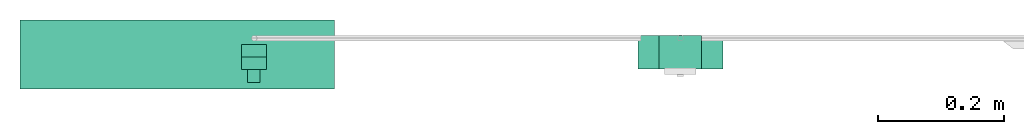
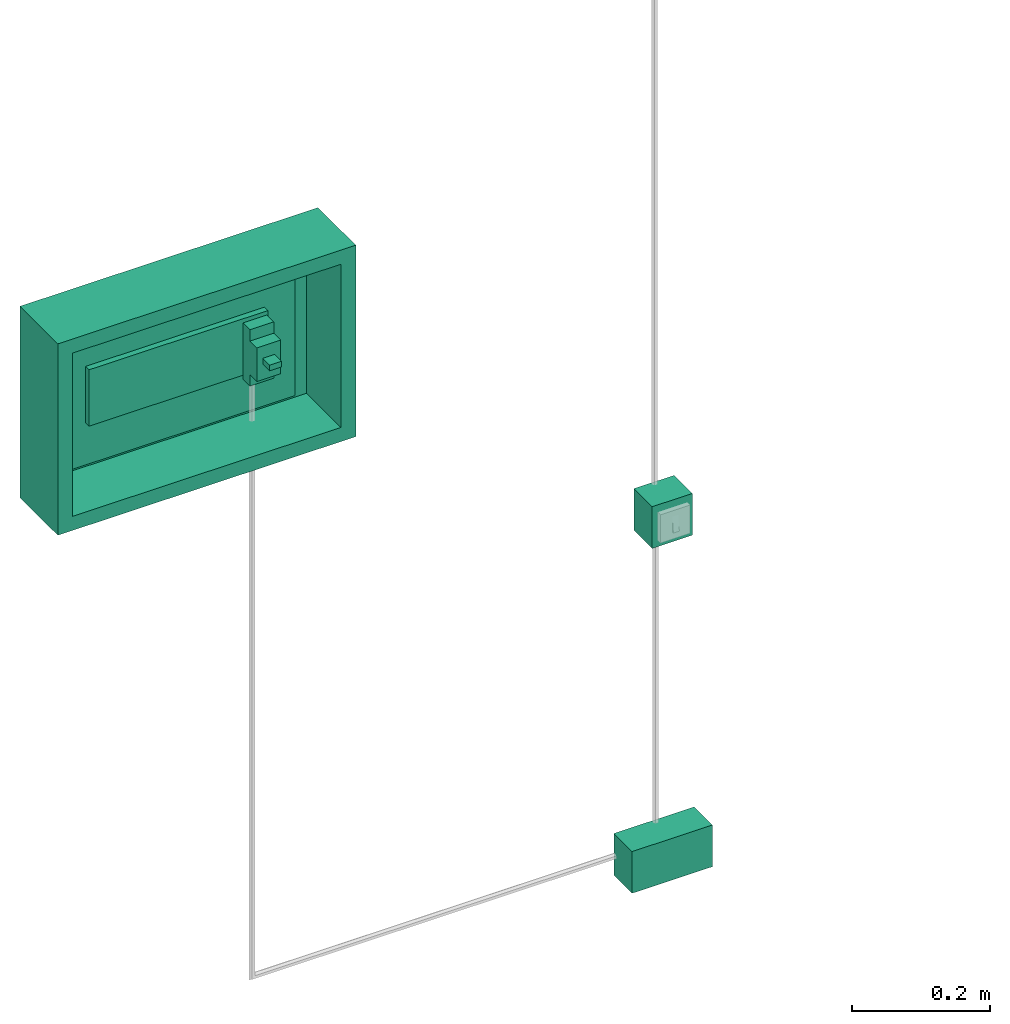
# One storey, part 1 of 4: 2 junction boxes, 1 distribution board, 1 protective device.
"""IFC4X3_ADD2 building model written with IfcOpenShell, lengths in metres."""

from ifc_helpers import new_model, entity, si_unit, converted_unit, frame, origin_with_axes, origin_2d_with_axis, place, context, subcontext, project, spatial, indexed_curve, outline, extrude, source, transform, mapped, type_object, type_shapes, element, save


model = new_model("IFC4X3_ADD2")

# Units and contexts
model_context = context("Model", 3, precision=1e-05, world=origin_with_axes())
plan_context = context("Plan", 2, precision=1e-05, world=origin_2d_with_axis())
body_context = subcontext(model_context, "Body", "Model", "MODEL_VIEW")
ifc_project = project(units=[si_unit("VOLUMEUNIT", "CUBIC_METRE"), si_unit("LENGTHUNIT", "METRE"), converted_unit("PLANEANGLEUNIT", "degree", entity("IfcReal", 0.0174532925199433), si_unit("PLANEANGLEUNIT", "RADIAN"), dimensions=[0, 0, 0, 0, 0, 0, 0]), si_unit("AREAUNIT", "SQUARE_METRE")], contexts=[model_context, plan_context])

# Site, building, storey
site_placement = place(None, origin_with_axes())
site = spatial("IfcSite", under=ifc_project, at=site_placement)
building_placement = place(site_placement, origin_with_axes())
building = spatial("IfcBuilding", under=site, at=building_placement, Name="Building")
storey_placement = place(building_placement, origin_with_axes())
storey = spatial("IfcBuildingStorey", under=building, at=storey_placement, Name="Storey")

# Distribution board
distribution_board_type = type_object("IfcDistributionBoardType", Name="DistributionBoard", PredefinedType="SWITCHBOARD")
shared_shape_1 = source(origin_with_axes(), body_context, "Body", "SweptSolid", [
    extrude(outline(indexed_curve([(0.0, 0.410369992256165), (0.5, 0.410369992256165), (0.5, 0.749999940395355), (0.0, 0.749999940395355), (0.0, 0.410369992256165)])), frame((0.00140758976340294, -0.000603213906288147, -0.411670565605164), z_axis=(0.0, -1.0, 7.54979012640433e-08), x_axis=(1.0, 0.0, 0.0)), (0.0, 0.0, 1.0), 0.00999999977648258),
    extrude(outline(indexed_curve([(0.0, 0.0), (0.300000011920929, 0.0), (0.300000011920929, 0.100000001490116), (0.0, 0.100000001490116), (0.0, 0.0)])), frame((0.100033104419708, -0.020603196695447, 0.109312906861305), z_axis=(0.0, -1.0, 7.54979012640433e-08), x_axis=(1.0, 0.0, 0.0)), (0.0, 0.0, 1.0), 0.00999999977648258),
    extrude(outline(indexed_curve([(-0.0986255258321762, 0.208527132868767), (0.401374489068985, 0.208527132868767), (0.401374489068985, -0.131102800369263), (-0.0986255258321762, -0.131102800369263), (-0.0986255258321762, 0.208527132868767)]), holes=[indexed_curve([(-0.0736255198717117, 0.183527141809464), (0.376374483108521, 0.183527126908302), (0.376374512910843, -0.106102764606476), (-0.0736255273222923, -0.106102764606476), (-0.0736255198717117, 0.183527141809464)])]), frame((0.100033104419708, -0.0106031745672226, 0.129802241921425), z_axis=(0.0, -1.0, 7.54979012640433e-08), x_axis=(1.0, 0.0, 0.0)), (0.0, 0.0, 1.0), 0.100000001490116),
    extrude(outline(indexed_curve([(-0.0486255288124084, 0.463084757328033), (0.351374477148056, 0.463084757328033), (0.351374477148056, 0.198454901576042), (-0.0486255288124084, 0.198454901576042), (-0.0486255288124084, 0.463084757328033)])), frame((0.100033104419708, -0.010603204369545, -0.163978442549706), z_axis=(0.0, -1.0, 7.54979012640433e-08), x_axis=(1.0, 0.0, 0.0)), (0.0, 0.0, 1.0), 0.00999999977648258),
])
type_shapes(distribution_board_type, [shared_shape_1])
distribution_board_placement = place(storey_placement, frame((0.0, 0.119209282100201, 1.39999997615814), z_axis=(0.0, 0.0, 1.0), x_axis=(1.0, 0.0, 0.0)))
element("IfcDistributionBoard", 1, at=distribution_board_placement, inside=storey, type_object=distribution_board_type, Name="DistributionBoard", context=body_context, shape_type="MappedRepresentation", body=[
    mapped(shared_shape_1, transform((0.0, 0.0, 0.0), x_axis=(1.0, 0.0, 0.0), y_axis=(0.0, 1.0, 0.0), z_axis=(0.0, 0.0, 1.0), scale=1.0)),
])

# Protective device
protective_device_type = type_object("IfcProtectiveDeviceType", Name="Breaker16A", PredefinedType="CIRCUITBREAKER")
shared_shape_2 = source(origin_with_axes(), body_context, "Body", "SweptSolid", [
    extrude(outline(indexed_curve([(0.0, 0.100000001490116), (0.0399999991059303, 0.100000001490116), (0.0399999991059303, 0.0), (0.0, 0.0), (0.0, 0.100000001490116)])), frame((0.0, 0.0, 0.0), z_axis=(0.0, -1.0, -4.37113882867379e-08), x_axis=(1.0, 0.0, 0.0)), (0.0, 0.0, 1.0), 0.0199999995529652),
    extrude(outline(indexed_curve([(0.0, 0.0200349669903517), (0.0399999991059303, 0.0200349669903517), (0.0399999991059303, 0.0797577872872353), (0.0, 0.0797577872872353), (0.0, 0.0200349669903517)])), frame((0.0, -0.0199999809265137, 0.0), z_axis=(0.0, -1.0, 7.54979012640433e-08), x_axis=(1.0, 0.0, 0.0)), (0.0, 0.0, 1.0), 0.0199999995529652),
    extrude(outline(indexed_curve([(0.00999999977648258, 0.0477925762534142), (0.0299999993294477, 0.0477925762534142), (0.0299999993294477, 0.0577925741672516), (0.00999999977648258, 0.0577925741672516), (0.00999999977648258, 0.0477925762534142)])), frame((0.0, -0.0399999618530273, 0.0), z_axis=(0.0, -1.0, 7.54979012640433e-08), x_axis=(1.0, 0.0, 0.0)), (0.0, 0.0, 1.0), 0.0199999995529652),
])
type_shapes(protective_device_type, [shared_shape_2])
protective_device_placement = place(storey_placement, frame((0.353246033191681, 0.0796492770314217, 1.50931286811829), z_axis=(0.0, 0.0, 1.0), x_axis=(1.0, 0.0, 0.0)))
element("IfcProtectiveDevice", 2, at=protective_device_placement, inside=storey, type_object=protective_device_type, Name="Breaker16A", context=body_context, shape_type="MappedRepresentation", body=[
    mapped(shared_shape_2, transform((0.0, 0.0, 0.0), x_axis=(1.0, 0.0, 0.0), y_axis=(0.0, 1.0, 0.0), z_axis=(0.0, 0.0, 1.0), scale=1.0)),
])

# Junction boxes
junction_box_type_1 = type_object("IfcJunctionBoxType", Name="504E-135x74x53", PredefinedType="POWER")
shared_shape_3 = source(origin_with_axes(), body_context, "Body", "SweptSolid", [
    extrude(outline(indexed_curve([(0.0, 0.0740000009536743), (0.135000005364418, 0.0740000009536743), (0.135000005364418, 0.0), (0.0, 0.0), (0.0, 0.0740000009536743)])), frame((0.0, 0.0, 0.0), z_axis=(0.0, -1.0, -4.37113882867379e-08), x_axis=(1.0, 0.0, 0.0)), (0.0, 0.0, 1.0), 0.0529999993741512),
])
type_shapes(junction_box_type_1, [shared_shape_3])
junction_box_1_placement = place(storey_placement, frame((0.983614861965179, 0.0940137356519699, 0.400000005960464), z_axis=(0.0, 0.0, 1.0), x_axis=(1.0, 0.0, 0.0)))
element("IfcJunctionBox", 3, at=junction_box_1_placement, inside=storey, type_object=junction_box_type_1, Name="504E-135x74x53", context=body_context, shape_type="MappedRepresentation", body=[
    mapped(shared_shape_3, transform((0.0, 0.0, 0.0), x_axis=(1.0, 0.0, 0.0), y_axis=(0.0, 1.0, 0.0), z_axis=(0.0, 0.0, 1.0), scale=1.0)),
])
junction_box_type_2 = type_object("IfcJunctionBoxType", Name="503E-74x74x53", PredefinedType="POWER")
shared_shape_4 = source(origin_with_axes(), body_context, "Body", "SweptSolid", [
    extrude(outline(indexed_curve([(0.0, 0.0), (0.0675000101327896, 0.0), (0.0675000101327896, 0.0740000009536743), (0.0, 0.0740000009536743), (0.0, 0.0)])), frame((0.0, 0.0, 0.0), z_axis=(0.0, -1.0, -4.37113882867379e-08), x_axis=(1.0, 0.0, 0.0)), (0.0, 0.0, 1.0), 0.0529999993741512),
])
type_shapes(junction_box_type_2, [shared_shape_4])
junction_box_2_placement = place(storey_placement, frame((1.01736497879028, 0.0940137356519699, 1.0), z_axis=(0.0, 0.0, 1.0), x_axis=(1.0, 0.0, 0.0)))
element("IfcJunctionBox", 4, at=junction_box_2_placement, inside=storey, type_object=junction_box_type_2, Name="503E-74x74x53", context=body_context, shape_type="MappedRepresentation", body=[
    mapped(shared_shape_4, transform((0.0, 0.0, 0.0), x_axis=(1.0, 0.0, 0.0), y_axis=(0.0, 1.0, 0.0), z_axis=(0.0, 0.0, 1.0), scale=1.0)),
])

save(model, "model.ifc")
